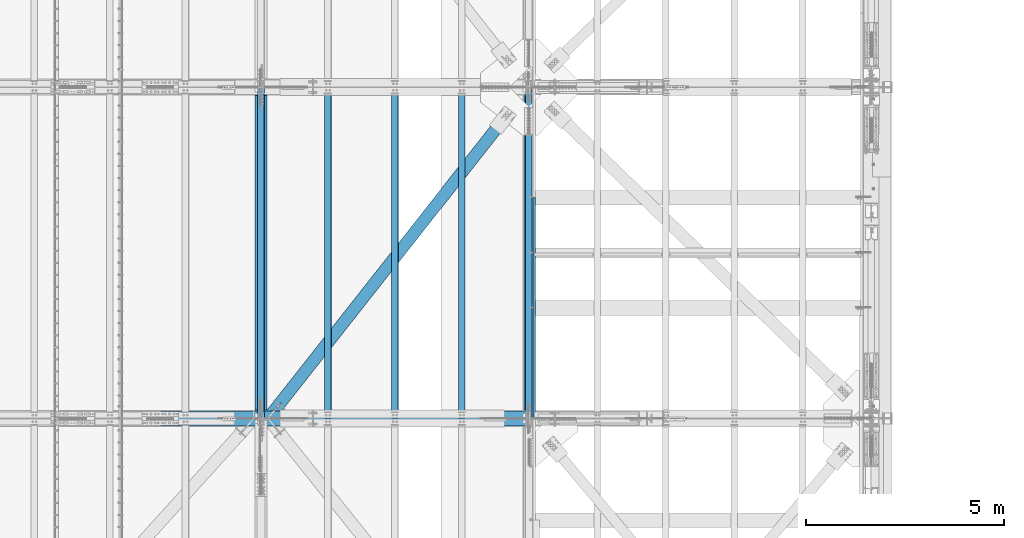
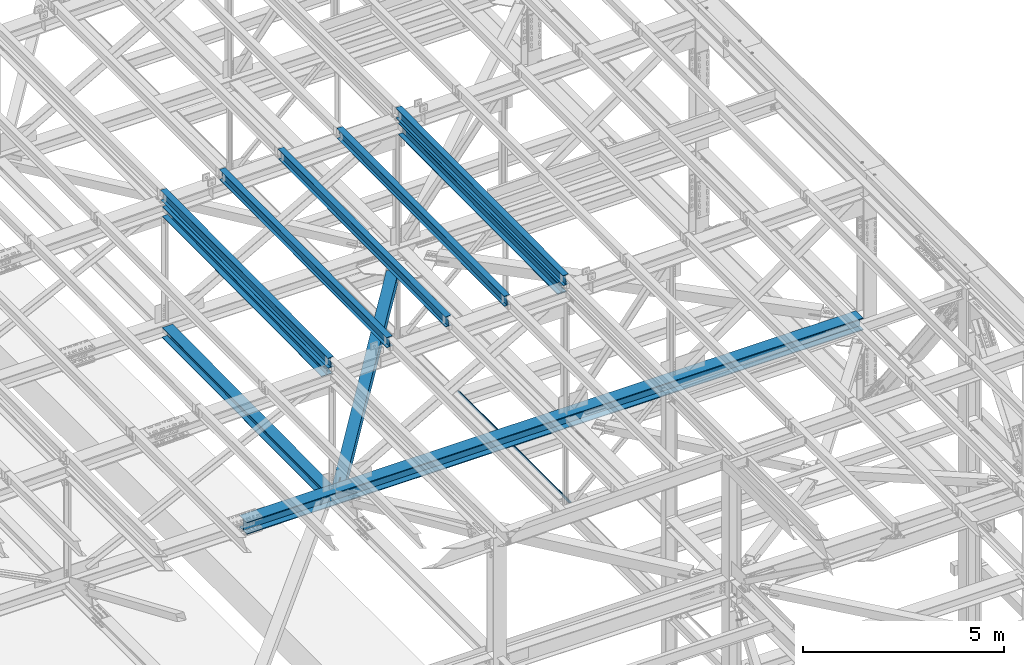
# One storey, part 1836 of 3843: 11 beams, 11 elements without a shape of their own.
"""IFC2X3 building model written with IfcOpenShell, lengths in millimetres."""

from ifc_helpers import new_model, si_unit, frame, origin_with_axes, place, context, subcontext, project, spatial, faceted_brep, material, type_object, element, aggregate, save


model = new_model("IFC2X3")

# Units and contexts
model_context = context("Model", 3, precision=1e-05, world=origin_with_axes())
body_context = subcontext(model_context, "Body", "Model", "MODEL_VIEW")
ifc_project = project(units=[si_unit("LENGTHUNIT", "METRE", prefix="MILLI"), si_unit("AREAUNIT", "SQUARE_METRE"), si_unit("VOLUMEUNIT", "CUBIC_METRE"), si_unit("MASSUNIT", "GRAM", prefix="KILO"), si_unit("TIMEUNIT", "SECOND"), si_unit("PLANEANGLEUNIT", "RADIAN"), si_unit("SOLIDANGLEUNIT", "STERADIAN"), si_unit("THERMODYNAMICTEMPERATUREUNIT", "DEGREE_CELSIUS"), si_unit("LUMINOUSINTENSITYUNIT", "LUMEN")], contexts=[model_context])

# Site, building, storey
site_placement = place(None, origin_with_axes())
site = spatial("IfcSite", under=ifc_project, at=site_placement, CompositionType="ELEMENT")
building_placement = place(site_placement, origin_with_axes())
building = spatial("IfcBuilding", under=site, at=building_placement, Name="Undefined", CompositionType="ELEMENT")
storey_placement = place(building_placement, origin_with_axes())
storey = spatial("IfcBuildingStorey", under=building, at=storey_placement, Name="Undefined", CompositionType="ELEMENT", Elevation=0.0)

# Assembly, beam
assembly_1_placement = place(storey_placement, origin_with_axes())
assembly_1 = element("IfcElementAssembly", 1, at=assembly_1_placement, inside=storey, Name="BEAM", AssemblyPlace="NOTDEFINED", PredefinedType="RIGID_FRAME")
ifc_material_1 = material(Name="STEEL/A992")
beam_type_1 = type_object("IfcBeamType", Name="W12X26", PredefinedType="NOTDEFINED")
beam_1_placement = place(assembly_1_placement, frame((77009.5092623596, 33844.5037463782, 46448.9366407137), z_axis=(-0.0211520979019697, -0.00640368699966348, 0.999755760947221), x_axis=(0.0, 0.999979487008501, 0.00640512000005479)))
beam_1 = element("IfcBeam", 2, at=beam_1_placement, type_object=beam_type_1, material=ifc_material_1, Name="BEAM", ObjectType="W12X26", context=body_context, shape_type="Brep", body=[
    faceted_brep([(12.689076294766, 82.5500000012398, -155.57500000007), (12.7500726644503, 82.5500000011962, -146.050000000076), (8344.12097401555, 82.5500000007742, -146.04999998011), (8344.05997764586, 82.5500000008178, -155.574999980112), (12.7608267468313, 3.17500000075961, -146.050000000032), (8344.13172809793, 3.1750000003376, -146.049999980067), (14.6313820839132, 3.17499999927531, 146.050000000097), (8346.002283435, 3.17499999885331, 146.050000020055), (14.6206280015249, 82.5499999997119, 146.050000000068), (8345.99152935263, 82.5499999992899, 146.050000020026), (14.6816243712165, 82.5499999996682, 155.57500000007), (8346.05252572231, 82.5499999992462, 155.575000020035), (14.7039928625672, -82.5500000012398, 155.575000000143), (8346.07489421367, -82.5500000016618, 155.575000020108), (14.642996492883, -82.5500000011962, 146.050000000141), (8346.01389784398, -82.5500000016182, 146.050000020099), (14.6322424104947, -3.17500000075961, 146.050000000105), (8346.0031437616, -3.17500000118162, 146.050000020063), (12.7616870734273, -3.17499999927531, -146.050000000039), (8344.13258842452, -3.17499999969732, -146.049999980074), (12.7724411558011, -82.5499999997119, -146.049999999996), (8344.1433425069, -82.5500000001339, -146.04999998003), (12.7114447861168, -82.5499999996537, -155.574999999997), (8344.08234613721, -82.5500000000902, -155.574999980032)], [[[0, 1, 2, 3]], [[1, 4, 5, 2]], [[4, 6, 7, 5]], [[6, 8, 9, 7]], [[8, 10, 11, 9]], [[10, 12, 13, 11]], [[12, 14, 15, 13]], [[14, 16, 17, 15]], [[16, 18, 19, 17]], [[18, 20, 21, 19]], [[20, 22, 23, 21]], [[22, 0, 3, 23]], [[5, 7, 9, 11, 13, 15, 17, 19, 21, 23, 3, 2]], [[22, 20, 18, 16, 14, 12, 10, 8, 6, 4, 1, 0]]]),
])
aggregate(assembly_1, [beam_1])

assembly_2_placement = place(storey_placement, origin_with_axes())
assembly_2 = element("IfcElementAssembly", 3, at=assembly_2_placement, inside=storey, Name="BEAM", AssemblyPlace="NOTDEFINED", PredefinedType="RIGID_FRAME")
beam_2_placement = place(assembly_2_placement, frame((70253.1092623499, 33844.311835066, 46302.7314229001), z_axis=(-0.021152098167775, -0.00763724799704507, 0.999747098613511), x_axis=(0.0, 0.999970818655236, 0.00763949199736622)))
beam_2 = element("IfcBeam", 4, at=beam_2_placement, type_object=beam_type_1, material=ifc_material_1, Name="BEAM", ObjectType="W12X26", context=body_context, shape_type="Brep", body=[
    faceted_brep([(12.6870316760251, 82.5500000001484, -155.575000000455), (12.7597785946491, 82.550000000163, -146.050000000432), (8344.20286729686, 82.5499999999884, -146.049999991745), (8344.13012037824, 82.5499999999593, -155.574999991768), (12.7726043807052, 3.17499999974098, -146.050000000367), (8344.21569308292, 3.17499999956635, -146.049999991679), (15.003509885275, 3.1750000002794, 146.050000000403), (8346.44659858748, 3.17500000009022, 146.050000009098), (14.9906840992262, 82.5500000007014, 146.050000000338), (8346.43377280144, 82.5500000005122, 146.050000009032), (15.0634310178502, 82.550000000716, 155.575000000368), (8346.50651972007, 82.5500000005268, 155.575000009056), (15.0901086528393, -82.550000000163, 155.575000000499), (8346.53319735506, -82.5500000003522, 155.575000009187), (15.0173617342152, -82.5500000001775, 146.050000000476), (8346.46045043643, -82.5500000003522, 146.050000009163), (15.0045359481592, -3.17499999977008, 146.05000000041), (8346.44762465037, -3.1749999999447, 146.050000009105), (12.7736304435894, -3.17500000029395, -146.050000000367), (8344.2167191458, -3.17500000046857, -146.049999991672), (12.7864562296381, -82.550000000716, -146.050000000301), (8344.22954493185, -82.5500000009051, -146.049999991606), (12.7137093110141, -82.5500000007305, -155.575000000317), (8344.15679801322, -82.5500000009197, -155.574999991622)], [[[0, 1, 2, 3]], [[1, 4, 5, 2]], [[4, 6, 7, 5]], [[6, 8, 9, 7]], [[8, 10, 11, 9]], [[10, 12, 13, 11]], [[12, 14, 15, 13]], [[14, 16, 17, 15]], [[16, 18, 19, 17]], [[18, 20, 21, 19]], [[20, 22, 23, 21]], [[22, 0, 3, 23]], [[5, 7, 9, 11, 13, 15, 17, 19, 21, 23, 3, 2]], [[22, 20, 18, 16, 14, 12, 10, 8, 6, 4, 1, 0]]]),
])
aggregate(assembly_2, [beam_2])

assembly_3_placement = place(storey_placement, origin_with_axes())
assembly_3 = element("IfcElementAssembly", 5, at=assembly_3_placement, inside=storey, Name="BEAM", AssemblyPlace="NOTDEFINED", PredefinedType="RIGID_FRAME")
beam_3_placement = place(assembly_3_placement, frame((75320.4092622856, 33844.4416263247, 46412.3852542388), z_axis=(-0.0211520977008331, -0.00680297999754112, 0.999753123639035), x_axis=(0.0, 0.999976849101475, 0.00680450300069029)))
beam_3 = element("IfcBeam", 6, at=beam_3_placement, type_object=beam_type_1, material=ifc_material_1, Name="BEAM", ObjectType="W12X26", context=body_context, shape_type="Brep", body=[
    faceted_brep([(12.6884123323835, 82.5500000002066, -155.57499999999), (12.7532122229532, 82.5500000002212, -146.049999999974), (8344.14609148617, 82.5500000006286, -146.050000019), (8344.0812915956, 82.5500000006141, -155.575000019009), (12.7646368925271, 3.17499999979918, -146.050000000163), (8344.15751615575, 3.17500000020664, -146.050000019182), (14.7518335368368, 3.17500000025029, 146.050000000105), (8346.14471280005, 3.17500000065775, 146.049999981093), (14.7404088672629, 82.5500000006723, 146.050000000294), (8346.13328813048, 82.5500000010798, 146.049999981282), (14.8052087578326, 82.5500000006869, 155.575000000295), (8346.19808802105, 82.5500000010943, 155.574999981283), (14.8289720705434, -82.5500000001921, 155.574999999924), (8346.22185133376, -82.5499999997846, 155.574999980912), (14.7641721799737, -82.5500000001921, 146.049999999916), (8346.1570514432, -82.5499999997846, 146.049999980904), (14.7527475103925, -3.17499999978463, 146.05000000009), (8346.14562677362, -3.17499999937718, 146.049999981078), (12.7655508660973, -3.17500000023574, -146.050000000178), (8344.15843012932, -3.17499999982829, -146.05000001919), (12.7769755356712, -82.5500000006577, -146.050000000359), (8344.16985479889, -82.5500000002503, -146.050000019372), (12.7121756450942, -82.5500000006723, -155.575000000368), (8344.10505490832, -82.5500000002648, -155.57500001938)], [[[0, 1, 2, 3]], [[1, 4, 5, 2]], [[4, 6, 7, 5]], [[6, 8, 9, 7]], [[8, 10, 11, 9]], [[10, 12, 13, 11]], [[12, 14, 15, 13]], [[14, 16, 17, 15]], [[16, 18, 19, 17]], [[18, 20, 21, 19]], [[20, 22, 23, 21]], [[22, 0, 3, 23]], [[5, 7, 9, 11, 13, 15, 17, 19, 21, 23, 3, 2]], [[22, 20, 18, 16, 14, 12, 10, 8, 6, 4, 1, 0]]]),
])
aggregate(assembly_3, [beam_3])

assembly_4_placement = place(storey_placement, origin_with_axes())
assembly_4 = element("IfcElementAssembly", 7, at=assembly_4_placement, inside=storey, Name="BEAM", AssemblyPlace="NOTDEFINED", PredefinedType="RIGID_FRAME")
beam_4_placement = place(assembly_4_placement, frame((73631.3092622709, 33844.3886235106, 46375.833919875), z_axis=(-0.0211520979699417, -0.00714367000215133, 0.999750747301731), x_axis=(0.0, 0.999974472239613, 0.00714526900171218)))
beam_4 = element("IfcBeam", 8, at=beam_4_placement, type_object=beam_type_1, material=ifc_material_1, Name="BEAM", ObjectType="W12X26", context=body_context, shape_type="Brep", body=[
    faceted_brep([(12.6878474664045, 82.5500000001484, -155.575000000295), (12.7558926638667, 82.550000000163, -146.050000000258), (8344.16857493095, 82.5500000000029, -146.049999992319), (8344.10052973349, 82.5499999999884, -155.57499999235), (12.7678895037752, 3.17499999972642, -146.050000000512), (8344.18057177086, 3.17499999956635, -146.049999992567), (14.8546088926523, 3.17500000029395, 146.050000000534), (8346.26729115974, 3.17500000011933, 146.050000008479), (14.8426120527365, 82.5500000007305, 146.050000000781), (8346.25529431982, 82.5500000005559, 146.050000008727), (14.9106572501987, 82.5500000007305, 155.575000000819), (8346.32333951729, 82.5500000005704, 155.575000008757), (14.9356106772175, -82.5500000001775, 155.575000000295), (8346.34829294431, -82.5500000003522, 155.575000008241), (14.8675654797553, -82.5500000001921, 146.050000000265), (8346.28024774685, -82.5500000003522, 146.05000000821), (14.8555686398468, -3.17499999975553, 146.050000000512), (8346.26825090693, -3.1749999999156, 146.050000008458), (12.7688492509697, -3.17500000029395, -146.050000000527), (8344.18153151806, -3.17500000046857, -146.049999992581), (12.7808460908855, -82.5500000007305, -146.050000000781), (8344.19352835797, -82.5500000009051, -146.049999992836), (12.7128008934233, -82.5500000007596, -155.575000000812), (8344.12548316051, -82.5500000009342, -155.574999992867)], [[[0, 1, 2, 3]], [[1, 4, 5, 2]], [[4, 6, 7, 5]], [[6, 8, 9, 7]], [[8, 10, 11, 9]], [[10, 12, 13, 11]], [[12, 14, 15, 13]], [[14, 16, 17, 15]], [[16, 18, 19, 17]], [[18, 20, 21, 19]], [[20, 22, 23, 21]], [[22, 0, 3, 23]], [[5, 7, 9, 11, 13, 15, 17, 19, 21, 23, 3, 2]], [[22, 20, 18, 16, 14, 12, 10, 8, 6, 4, 1, 0]]]),
])
aggregate(assembly_4, [beam_4])

assembly_5_placement = place(storey_placement, origin_with_axes())
assembly_5 = element("IfcElementAssembly", 9, at=assembly_5_placement, inside=storey, Name="BEAM", AssemblyPlace="NOTDEFINED", PredefinedType="RIGID_FRAME")
beam_5_placement = place(assembly_5_placement, frame((71942.2092622841, 33844.3458973389, 46339.2826504811), z_axis=(-0.0211520982902439, -0.0074183040013959, 0.999748747187844), x_axis=(0.0, 0.999972471688233, 0.00741996399768687)))
beam_5 = element("IfcBeam", 10, at=beam_5_placement, type_object=beam_type_1, material=ifc_material_1, Name="BEAM", ObjectType="W12X26", context=body_context, shape_type="Brep", body=[
    faceted_brep([(12.6873932488452, 82.5499999997992, -155.574999999422), (12.7580545389283, 82.5499999998574, -146.049999999443), (8344.1874047676, 82.5499999993917, -146.049999977913), (8344.11674347752, 82.5499999993481, -155.574999977885), (12.7705126140499, 3.17499999940628, -146.049999999603), (8344.19986284273, 3.17499999894062, -146.049999978066), (14.9374588432474, 3.17500000064319, 146.049999999675), (8346.36680907193, 3.17500000019209, 146.05000002122), (14.9250007681185, 82.5500000010943, 146.049999999843), (8346.35435099681, 82.5500000006432, 146.050000021372), (14.9956620582088, 82.550000001138, 155.574999999815), (8346.42501228688, 82.5500000006723, 155.575000021352), (15.0215748544579, -82.5499999997701, 155.574999999488), (8346.45092508315, -82.5500000002357, 155.575000021025), (14.9509135643821, -82.5499999998283, 146.049999999515), (8346.38026379306, -82.5500000002794, 146.050000021045), (14.9384554892531, -3.17499999937718, 146.049999999668), (8346.36780571794, -3.17499999982829, 146.050000021205), (12.7715092600556, -3.17500000061409, -146.049999999625), (8344.20085948874, -3.17500000107975, -146.04999997808), (12.7839673351846, -82.5500000010652, -146.04999999977), (8344.21331756387, -82.5500000015309, -146.049999978248), (12.7133060451015, -82.5500000011089, -155.57499999975), (8344.14265627378, -82.55000000156, -155.574999978213)], [[[0, 1, 2, 3]], [[1, 4, 5, 2]], [[4, 6, 7, 5]], [[6, 8, 9, 7]], [[8, 10, 11, 9]], [[10, 12, 13, 11]], [[12, 14, 15, 13]], [[14, 16, 17, 15]], [[16, 18, 19, 17]], [[18, 20, 21, 19]], [[20, 22, 23, 21]], [[22, 0, 3, 23]], [[5, 7, 9, 11, 13, 15, 17, 19, 21, 23, 3, 2]], [[22, 20, 18, 16, 14, 12, 10, 8, 6, 4, 1, 0]]]),
])
aggregate(assembly_5, [beam_5])

assembly_6_placement = place(storey_placement, origin_with_axes())
assembly_6 = element("IfcElementAssembly", 11, at=assembly_6_placement, inside=storey, Name="BENT_PLATE", AssemblyPlace="NOTDEFINED", PredefinedType="RIGID_FRAME")
ifc_material_2 = material(Name="STEEL/A36")
beam_type_2 = type_object("IfcBeamType", PredefinedType="NOTDEFINED")
beam_6_placement = place(assembly_6_placement, frame((77179.4875000007, 36640.29375, 39627.1749999995), z_axis=(0.0, 1.0, 0.0), x_axis=(-1.0, 0.0, 0.0)))
beam_6 = element("IfcBeam", 12, at=beam_6_placement, type_object=beam_type_2, material=ifc_material_2, Name="BENT_PLATE", context=body_context, shape_type="Brep", body=[
    faceted_brep([(0.0, -3.17500000000291, -2776.53750000001), (0.0, -3.17500000000291, 2776.53750000001), (0.0, 3.17500000000291, 2776.53750000001), (0.0, 3.17500000000291, -2776.53750000001), (69.8500000010827, 3.17500000000291, 2776.53750000001), (69.8500000010827, 3.17500000000291, -2776.53750000001), (76.2000000010739, -3.17500000000291, -2776.53750000001), (76.2000000010739, -3.17500000000291, 2776.53750000001), (69.8500000011554, 73.0249999989392, 2776.53750000001), (69.8500000011554, 73.0249999989392, -2776.53750000001), (76.2000000011612, 73.0249999989246, 2776.53750000001), (76.2000000011612, 73.0249999989246, -2776.53750000001)], [[[0, 1, 2, 3]], [[3, 2, 4, 5]], [[1, 0, 6, 7]], [[5, 4, 8, 9]], [[4, 2, 1, 7, 10, 8]], [[7, 6, 11, 10]], [[6, 0, 3, 5, 9, 11]], [[10, 11, 9, 8]]]),
])
aggregate(assembly_6, [beam_6])

assembly_7_placement = place(storey_placement, origin_with_axes())
assembly_7 = element("IfcElementAssembly", 13, at=assembly_7_placement, inside=storey, Name="BEAM", AssemblyPlace="NOTDEFINED", PredefinedType="RIGID_FRAME")
beam_type_3 = type_object("IfcBeamType", Name="W14X120", PredefinedType="NOTDEFINED")
beam_7_placement = place(assembly_7_placement, frame((67716.3999999078, 33845.5, 42261.585053985), z_axis=(-0.00048281500021403, 0.0, 0.999999883444831), x_axis=(0.999999883444831, 0.0, 0.000482815000217081)))
beam_7 = element("IfcBeam", 14, at=beam_7_placement, type_object=beam_type_3, material=ifc_material_1, Name="BEAM", ObjectType="W14X120", context=body_context, shape_type="Brep", body=[
    faceted_brep([(6.34999999732827, -185.737500000003, -184.1500000003), (6.35000000674336, -185.737500000003, -160.33750000099), (6.34999999732827, -7.14375000000291, -160.337500000271), (6.34999999732827, -7.14375000000291, 160.337500000249), (6.35000000639411, -185.737500000003, 160.337500001014), (6.34999999734282, -185.737500000003, 184.150000000292), (6.34999999734282, 185.737500000003, 184.150000000292), (6.35000000639411, 185.737500000003, 160.337500001014), (6.34999999732827, 7.14375000000291, 160.337500000249), (6.34999999732827, 7.14375000000291, -160.337500000271), (6.35000000674336, 185.737500000003, -160.33750000099), (6.34999999732827, 185.737500000003, -184.1500000003), (17732.2881540681, -185.737500000003, -184.150000045403), (17732.2996511016, -185.737500000003, -160.337500045367), (17732.2996511016, -147.637500016623, -160.337500045367), (17732.2996511016, -7.14375000000291, -160.337500045367), (17732.4544778199, -7.14375000000291, 160.337499955145), (17732.4544778199, -147.637500016623, 160.337499955145), (17732.4544778199, -185.737500000003, 160.337499955145), (17732.4659748534, -185.737500000003, 184.149999955182), (17732.4659748534, -147.637500016623, 184.149999955182), (17732.4659748534, 147.637499983372, 184.149999955182), (17732.4659748534, 185.737500000003, 184.149999955182), (17732.4544778199, 185.737500000003, 160.337499955145), (17732.4544778199, 147.637499983372, 160.337499955145), (17732.4544778199, 7.14375000000291, 160.337499955145), (17732.4356630119, 7.14375000000291, 121.368524726146), (17732.3184451861, 7.14375000000291, -121.411446977356), (17732.2996511016, 7.14375000000291, -160.337500045367), (17732.2996511016, 147.637499983372, -160.337500045367), (17732.2996511016, 185.737500000003, -160.337500045367), (17732.2881540681, 185.737500000003, -184.150000045403), (17732.2881540681, -147.637500016623, -184.150000045403), (17732.2881540681, 147.637499983372, -184.150000045403)], [[[0, 1, 2, 3, 4, 5, 6, 7, 8, 9, 10, 11]], [[1, 0, 12, 13]], [[2, 1, 13, 14, 15]], [[3, 2, 15, 16]], [[4, 3, 16, 17, 18]], [[5, 4, 18, 19]], [[6, 5, 19, 20, 21, 22]], [[7, 6, 22, 23]], [[8, 7, 23, 24, 25]], [[9, 8, 25, 26, 27, 28]], [[10, 9, 28, 29, 30]], [[11, 10, 30, 31]], [[29, 28, 27, 26, 25, 24, 23, 22, 21, 20, 19, 18, 17, 16, 15, 14, 13, 12, 32, 33, 31, 30]], [[0, 11, 31, 33, 32, 12]]]),
])
aggregate(assembly_7, [beam_7])

assembly_8_placement = place(storey_placement, origin_with_axes())
assembly_8 = element("IfcElementAssembly", 15, at=assembly_8_placement, inside=storey, AssemblyPlace="NOTDEFINED", PredefinedType="RIGID_FRAME")
ifc_material_3 = material()
beam_type_4 = type_object("IfcBeamType", Name="HSS12X12X3/4", PredefinedType="NOTDEFINED")
beam_8_placement = place(assembly_8_placement, frame((70434.2, 33845.4999998931, 42246.55), z_axis=(-0.785737878354052, 0.618559606278711, 0.0), x_axis=(0.618559606278724, 0.785737878354041, 0.0)))
beam_8 = element("IfcBeam", 16, at=beam_8_placement, type_object=beam_type_4, material=ifc_material_3, ObjectType="HSS12X12X3/4", context=body_context, shape_type="Brep", body=[
    faceted_brep([(241.301850900258, -152.400000000001, 14.2872176734309), (241.301850900258, -133.349999999999, 14.2872176734309), (497.314296196753, -133.349999999999, 14.286918472957), (497.314296196753, -152.400000000001, 14.286918472957), (502.781884611031, -133.349999999999, 13.1993408749477), (502.781884611031, -152.400000000001, 13.1993408749477), (507.417079711187, -133.349999999999, 10.1021946911569), (507.417079711187, -152.400000000001, 10.1021946911569), (510.51421506147, -133.349999999999, 5.46699235228152), (510.51421506147, -152.400000000001, 5.46699235228152), (497.314262801548, -152.400000000001, -14.2880815266617), (497.314262801548, -133.349999999999, -14.2880815266617), (263.797084396312, -133.349999999999, -14.2878086173878), (263.797084396312, -152.400000000001, -14.2878086173878), (502.781853758992, -152.400000000001, -13.2005167080933), (502.781853758992, -133.349999999999, -13.2005167080933), (507.417056098886, -152.400000000001, -10.1033813573449), (507.417056098886, -133.349999999999, -10.1033813573449), (510.514202283055, -152.400000000001, -5.4681862560974), (510.514202283055, -133.349999999999, -5.4681862560974), (511.601779880541, -152.400000000001, -0.000597840487898793), (511.601779880541, -133.349999999999, -0.000597840487898793), (241.301850900258, 133.349999999999, 14.2872176734309), (241.301850900258, 152.400000000001, 14.2872176734309), (497.314296196753, 152.400000000001, 14.286918472957), (497.314296196753, 133.349999999999, 14.286918472957), (502.781884611031, 152.400000000001, 13.1993408749477), (502.781884611031, 133.349999999999, 13.1993408749477), (507.417079711187, 152.400000000001, 10.1021946911569), (507.417079711187, 133.349999999999, 10.1021946911569), (510.51421506147, 152.400000000001, 5.46699235228152), (510.51421506147, 133.349999999999, 5.46699235228152), (497.314262801548, 133.349999999999, -14.2880815266617), (497.314262801548, 152.400000000001, -14.2880815266617), (263.797084396312, 152.400000000001, -14.2878086173878), (263.797084396312, 133.349999999999, -14.2878086173878), (502.781853758992, 133.349999999999, -13.2005167080933), (502.781853758992, 152.400000000001, -13.2005167080933), (507.417056098886, 133.349999999999, -10.1033813573449), (507.417056098886, 152.400000000001, -10.1033813573449), (510.514202283055, 133.349999999999, -5.4681862560974), (510.514202283055, 152.400000000001, -5.4681862560974), (511.601779880541, 133.349999999999, -0.000597840487898793), (511.601779880541, 152.400000000001, -0.000597840487898793), (9569.43132374003, -26.9864992151051, -133.350000029735), (9569.43132368661, -26.9864992151051, -152.400000029804), (9266.218811741, -26.9864992151051, -152.400000028872), (9266.21881179446, -26.9864992151051, -133.350000028811), (9260.75122205509, -25.8989280068199, -152.400000028858), (9260.75122210855, -25.8989280068199, -133.350000028797), (9256.11602333504, -22.8017872395794, -152.400000028836), (9256.1160233885, -22.8017872395794, -133.350000028768), (9253.01888256779, -18.1665885195325, -152.400000028843), (9253.01888262125, -18.1665885195325, -133.35000002876), (9251.93131135951, -12.6989988336354, -152.400000028829), (9251.93131141296, -12.6989988336354, -133.35000002876), (9253.01888256779, -7.23140991068067, -152.400000028843), (9253.01888262125, -7.23140991068067, -133.35000002876), (9256.11602333504, -2.59621119063377, -152.400000028836), (9256.1160233885, -2.59621119063377, -133.350000028768), (9260.75122205509, 0.500929576606723, -152.400000028858), (9260.75122210855, 0.500929576606723, -133.350000028797), (9266.218811741, 1.58850078489195, -152.400000028872), (9266.21881179446, 1.58850078489195, -133.350000028811), (9569.43132374003, 1.58850078489195, -133.350000029735), (9569.43132368661, 1.58850078489195, -152.400000029804), (9569.43132448789, 133.349999999999, 133.349999971222), (9569.43132374003, 133.349999999999, -133.350000029735), (9569.43132368661, 152.400000000001, -152.400000029804), (9569.43132454131, 152.400000000001, 152.399999971291), (9569.43132454131, 1.58850078489195, 152.399999971291), (9569.43132448789, 1.58850078489195, 133.349999971222), (9569.43132374003, -133.349999999999, -133.350000029735), (357.526894772687, 133.349999999999, -133.35000000157), (357.526894772687, -133.349999999999, -133.35000000157), (147.571575313908, -133.349999999999, 133.350000000013), (9569.43132448789, -133.349999999999, 133.349999971222), (9266.21881254292, 1.58850078489195, 133.349999972146), (9260.75122285704, 0.500929576606723, 133.349999972161), (9256.11602413698, -2.59621119063377, 133.349999972183), (9253.01888336972, -7.23140991068067, 133.34999997219), (9251.93131216144, -12.6989988336354, 133.34999997219), (9253.01888336972, -18.1665885195325, 133.34999997219), (9256.11602413698, -22.8017872395794, 133.349999972183), (9260.75122285704, -25.8989280068199, 133.349999972161), (9266.21881254292, -26.9864992151051, 133.349999972146), (9569.43132448789, -26.9864992151051, 133.349999971222), (147.571575313908, 133.349999999999, 133.350000000013), (9266.21881259639, 1.58850078489195, 152.399999972215), (9260.75122291049, 0.500929576606723, 152.399999972236), (9256.11602419044, -2.59621119063377, 152.399999972251), (9253.0188834232, -7.23140991068067, 152.399999972251), (9251.9313122149, -12.6989988336354, 152.399999972251), (9253.0188834232, -18.1665885195325, 152.399999972251), (9256.11602419044, -22.8017872395794, 152.399999972251), (9260.75122291049, -25.8989280068199, 152.399999972236), (9266.21881259639, -26.9864992151051, 152.399999972215), (9569.43132454131, -26.9864992151051, 152.399999971291), (9569.43132454131, -152.400000000001, 152.399999971291), (9569.43132368661, -152.400000000001, -152.400000029804), (372.523703305458, -152.400000000001, -152.400000001689), (372.523703305458, 152.400000000001, -152.400000001689), (132.574766781123, 152.400000000001, 152.40000000014), (132.574766781123, -152.400000000001, 152.40000000014)], [[[0, 1, 2, 3]], [[3, 2, 4, 5]], [[5, 4, 6, 7]], [[7, 6, 8, 9]], [[10, 11, 12, 13]], [[14, 15, 11, 10]], [[16, 17, 15, 14]], [[18, 19, 17, 16]], [[20, 21, 19, 18]], [[9, 8, 21, 20]], [[22, 23, 24, 25]], [[25, 24, 26, 27]], [[27, 26, 28, 29]], [[29, 28, 30, 31]], [[32, 33, 34, 35]], [[36, 37, 33, 32]], [[38, 39, 37, 36]], [[40, 41, 39, 38]], [[42, 43, 41, 40]], [[31, 30, 43, 42]], [[44, 45, 46, 47]], [[47, 46, 48, 49]], [[49, 48, 50, 51]], [[51, 50, 52, 53]], [[53, 52, 54, 55]], [[55, 54, 56, 57]], [[57, 56, 58, 59]], [[59, 58, 60, 61]], [[61, 60, 62, 63]], [[64, 63, 62, 65]], [[66, 67, 64, 65, 68, 69, 70, 71]], [[72, 44, 47, 49, 51, 53, 55, 57, 59, 61, 63, 64, 67, 73, 74]], [[6, 4, 2, 1, 75, 76, 72, 74, 12, 11, 15, 17, 19, 21, 8]], [[66, 71, 77, 78, 79, 80, 81, 82, 83, 84, 85, 86, 76, 75, 87]], [[70, 88, 77, 71]], [[89, 78, 77, 88]], [[90, 79, 78, 89]], [[91, 80, 79, 90]], [[92, 81, 80, 91]], [[93, 82, 81, 92]], [[94, 83, 82, 93]], [[95, 84, 83, 94]], [[96, 85, 84, 95]], [[97, 86, 85, 96]], [[98, 99, 45, 44, 72, 76, 86, 97]], [[68, 65, 62, 60, 58, 56, 54, 52, 50, 48, 46, 45, 99, 100, 101]], [[74, 73, 35, 34, 101, 100, 13, 12]], [[28, 26, 24, 23, 102, 69, 68, 101, 34, 33, 37, 39, 41, 43, 30]], [[98, 97, 96, 95, 94, 93, 92, 91, 90, 89, 88, 70, 69, 102, 103]], [[16, 14, 10, 13, 100, 99, 98, 103, 0, 3, 5, 7, 9, 20, 18]], [[103, 102, 23, 22, 87, 75, 1, 0]], [[38, 36, 32, 35, 73, 67, 66, 87, 22, 25, 27, 29, 31, 42, 40]]]),
])
aggregate(assembly_8, [beam_8])

assembly_9_placement = place(storey_placement, origin_with_axes())
assembly_9 = element("IfcElementAssembly", 17, at=assembly_9_placement, inside=storey, Name="BEAM", AssemblyPlace="NOTDEFINED", PredefinedType="RIGID_FRAME")
beam_type_5 = type_object("IfcBeamType", Name="W14X68", PredefinedType="NOTDEFINED")
beam_9_placement = place(assembly_9_placement, frame((77012.8, 33845.5, 46096.5120749074), z_axis=(0.0, -0.006405120000054, 0.999979487008501), x_axis=(0.0, 0.999979487008501, 0.00640512000005479)))
beam_9 = element("IfcBeam", 18, at=beam_9_placement, type_object=beam_type_5, material=ifc_material_1, Name="BEAM", ObjectType="W14X68", context=body_context, shape_type="Brep", body=[
    faceted_brep([(211.590510018606, 127.0, -177.799999999595), (211.712530057601, 127.0, -158.749999999578), (8143.02522501758, 127.0, -158.749999980573), (8142.90320497858, 127.0, -177.799999980591), (211.712530057601, 5.55624999999418, -158.749999999578), (8143.02522501758, 5.55624999999418, -158.749999980573), (213.746197374225, 5.55624999999418, 158.750000000626), (8145.0588923342, 5.55624999999418, 158.750000019631), (213.746197374225, 127.0, 158.750000000626), (8145.0588923342, 127.0, 158.750000019631), (213.868217413219, 127.0, 177.800000000636), (8145.18091237319, 127.0, 177.800000019641), (213.868217413219, -127.0, 177.800000000636), (8145.18091237319, -127.0, 177.800000019641), (213.746197374225, -127.0, 158.750000000626), (8145.0588923342, -127.0, 158.750000019631), (213.746197374225, -5.55624999999418, 158.750000000626), (8145.0588923342, -5.55624999999418, 158.750000019631), (211.712530057601, -5.55624999999418, -158.749999999578), (8143.02522501758, -5.55624999999418, -158.749999980573), (211.712530057601, -127.0, -158.749999999578), (8143.02522501758, -127.0, -158.749999980573), (211.590510018606, -127.0, -177.799999999595), (8142.90320497858, -127.0, -177.799999980591)], [[[0, 1, 2, 3]], [[1, 4, 5, 2]], [[4, 6, 7, 5]], [[6, 8, 9, 7]], [[8, 10, 11, 9]], [[10, 12, 13, 11]], [[12, 14, 15, 13]], [[14, 16, 17, 15]], [[16, 18, 19, 17]], [[18, 20, 21, 19]], [[20, 22, 23, 21]], [[22, 0, 3, 23]], [[5, 7, 9, 11, 13, 15, 17, 19, 21, 23, 3, 2]], [[22, 20, 18, 16, 14, 12, 10, 8, 6, 4, 1, 0]]]),
])
aggregate(assembly_9, [beam_9])

assembly_10_placement = place(storey_placement, origin_with_axes())
assembly_10 = element("IfcElementAssembly", 19, at=assembly_10_placement, inside=storey, Name="BEAM", AssemblyPlace="NOTDEFINED", PredefinedType="RIGID_FRAME")
beam_type_6 = type_object("IfcBeamType", Name="W12X65", PredefinedType="NOTDEFINED")
beam_10_placement = place(assembly_10_placement, frame((70256.4, 33845.5, 45950.2996849465), z_axis=(0.0, -0.00763949199736815, 0.999970818655236), x_axis=(0.0, 0.999970818655236, 0.00763949199736622)))
beam_10 = element("IfcBeam", 20, at=beam_10_placement, type_object=beam_type_6, material=ifc_material_1, Name="BEAM", ObjectType="W12X65", context=body_context, shape_type="Brep", body=[
    faceted_brep([(211.554787180714, 152.399999999994, -153.987500000803), (211.676067655302, 152.399999999994, -138.112500000745), (8143.05751608761, 152.399999999994, -138.112500011106), (8142.93623561302, 152.399999999994, -153.987500011164), (211.676067655302, 4.76249999999709, -138.112500000745), (8143.05751608761, 4.76249999999709, -138.112500011106), (213.786347913097, 4.76249999999709, 138.112500000221), (8145.16779634541, 4.76249999999709, 138.112499989868), (213.786347913097, 152.399999999994, 138.112500000221), (8145.16779634541, 152.399999999994, 138.112499989868), (213.907628387686, 152.399999999994, 153.987500000272), (8145.28907681999, 152.399999999994, 153.987499989926), (213.907628387686, -152.399999999994, 153.987500000272), (8145.28907681999, -152.399999999994, 153.987499989926), (213.786347913097, -152.399999999994, 138.112500000221), (8145.16779634541, -152.399999999994, 138.112499989868), (213.786347913097, -4.76249999999709, 138.112500000221), (8145.16779634541, -4.76249999999709, 138.112499989868), (211.676067655302, -4.76249999999709, -138.112500000745), (8143.05751608761, -4.76249999999709, -138.112500011106), (211.676067655302, -152.399999999994, -138.112500000745), (8143.05751608761, -152.399999999994, -138.112500011106), (211.554787180714, -152.399999999994, -153.987500000803), (8142.93623561302, -152.399999999994, -153.987500011164)], [[[0, 1, 2, 3]], [[1, 4, 5, 2]], [[4, 6, 7, 5]], [[6, 8, 9, 7]], [[8, 10, 11, 9]], [[10, 12, 13, 11]], [[12, 14, 15, 13]], [[14, 16, 17, 15]], [[16, 18, 19, 17]], [[18, 20, 21, 19]], [[20, 22, 23, 21]], [[22, 0, 3, 23]], [[5, 7, 9, 11, 13, 15, 17, 19, 21, 23, 3, 2]], [[22, 20, 18, 16, 14, 12, 10, 8, 6, 4, 1, 0]]]),
])
aggregate(assembly_10, [beam_10])

assembly_11_placement = place(storey_placement, origin_with_axes())
assembly_11 = element("IfcElementAssembly", 21, at=assembly_11_placement, inside=storey, Name="BEAM", AssemblyPlace="NOTDEFINED", PredefinedType="RIGID_FRAME")
beam_11_placement = place(assembly_11_placement, frame((70256.4, 33845.5, 42262.8114042285), z_axis=(0.0, -0.00764224599703449, 0.999970797611671), x_axis=(0.0, 0.999970797611671, 0.00764224599703225)))
beam_11 = element("IfcBeam", 22, at=beam_11_placement, type_object=beam_type_6, material=ifc_material_1, Name="BEAM", ObjectType="W12X65", context=body_context, shape_type="Brep", body=[
    faceted_brep([(197.266450295167, 152.399999999994, -153.987499999668), (197.38777449332, 152.399999999994, -138.112499999705), (8157.34522422605, 152.399999999994, -138.11250000001), (8157.22390002789, 152.399999999994, -153.987499999974), (197.38777449332, 4.76249999999709, -138.112499999705), (8157.34522422605, 4.76249999999709, -138.11250000001), (199.498815541287, 4.76249999999709, 138.112499999675), (8159.45626527401, 4.76249999999709, 138.11249999937), (199.498815541287, 152.399999999994, 138.112499999675), (8159.45626527401, 152.399999999994, 138.11249999937), (199.620139739447, 152.399999999994, 153.987499999639), (8159.57758947217, 152.399999999994, 153.987499999334), (199.620139739447, -152.399999999994, 153.987499999639), (8159.57758947217, -152.399999999994, 153.987499999334), (199.498815541287, -152.399999999994, 138.112499999675), (8159.45626527401, -152.399999999994, 138.11249999937), (199.498815541287, -4.76249999999709, 138.112499999675), (8159.45626527401, -4.76249999999709, 138.11249999937), (197.38777449332, -4.76249999999709, -138.112499999705), (8157.34522422605, -4.76249999999709, -138.11250000001), (197.38777449332, -152.399999999994, -138.112499999705), (8157.34522422605, -152.399999999994, -138.11250000001), (197.266450295167, -152.399999999994, -153.987499999668), (8157.22390002789, -152.399999999994, -153.987499999974)], [[[0, 1, 2, 3]], [[1, 4, 5, 2]], [[4, 6, 7, 5]], [[6, 8, 9, 7]], [[8, 10, 11, 9]], [[10, 12, 13, 11]], [[12, 14, 15, 13]], [[14, 16, 17, 15]], [[16, 18, 19, 17]], [[18, 20, 21, 19]], [[20, 22, 23, 21]], [[22, 0, 3, 23]], [[5, 7, 9, 11, 13, 15, 17, 19, 21, 23, 3, 2]], [[22, 20, 18, 16, 14, 12, 10, 8, 6, 4, 1, 0]]]),
])
aggregate(assembly_11, [beam_11])

save(model, "model.ifc")
